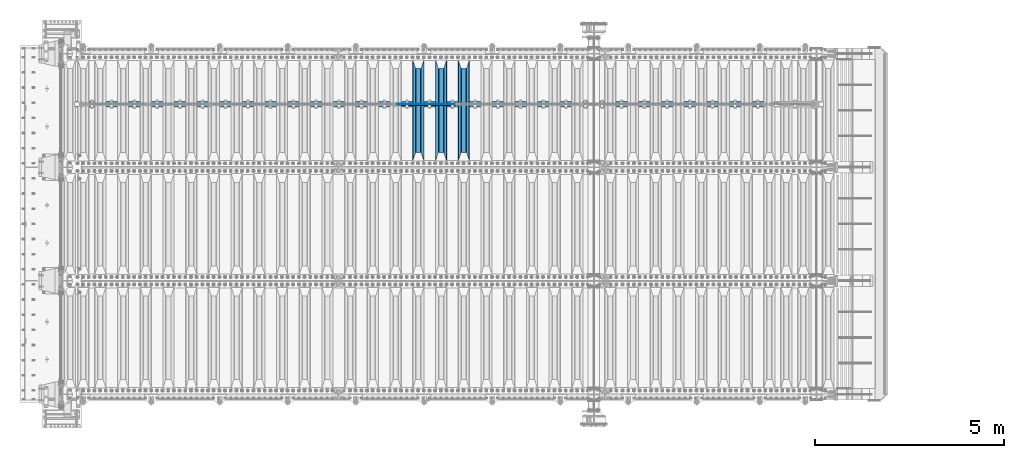
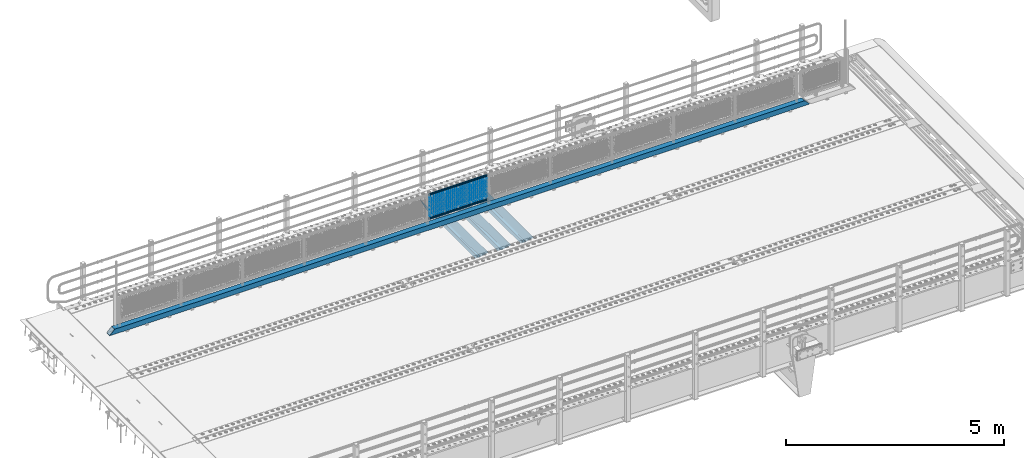
# One storey, part 134 of 270: 23 beams.
"""IFC2X3 building model written with IfcOpenShell, lengths in millimetres."""

from ifc_helpers import new_model, si_unit, frame, origin_with_axes, place, context, subcontext, project, spatial, faceted_brep, material, type_object, element, save


model = new_model("IFC2X3")

# Units and contexts
model_context = context("Model", 3, precision=1e-05, world=origin_with_axes())
body_context = subcontext(model_context, "Body", "Model", "MODEL_VIEW")
ifc_project = project(units=[si_unit("LENGTHUNIT", "METRE", prefix="MILLI"), si_unit("AREAUNIT", "SQUARE_METRE"), si_unit("VOLUMEUNIT", "CUBIC_METRE"), si_unit("MASSUNIT", "GRAM", prefix="KILO"), si_unit("TIMEUNIT", "SECOND"), si_unit("PLANEANGLEUNIT", "RADIAN"), si_unit("SOLIDANGLEUNIT", "STERADIAN"), si_unit("THERMODYNAMICTEMPERATUREUNIT", "DEGREE_CELSIUS"), si_unit("LUMINOUSINTENSITYUNIT", "LUMEN")], contexts=[model_context])

# Site, building, storey
site_placement = place(None, origin_with_axes())
site = spatial("IfcSite", under=ifc_project, at=site_placement, CompositionType="ELEMENT")
building_placement = place(site_placement, origin_with_axes())
building = spatial("IfcBuilding", under=site, at=building_placement, Name="Standard", CompositionType="ELEMENT")
storey_placement = place(building_placement, origin_with_axes())
storey = spatial("IfcBuildingStorey", under=building, at=storey_placement, Name="Undefined", CompositionType="ELEMENT", Elevation=0.0)

# Beams
ifc_material_1 = material(Name="STEEL/S355N")
beam_type_1 = type_object("IfcBeamType", PredefinedType="NOTDEFINED")
beam_1_placement = place(storey_placement, frame((10600.0, -17825.0, -115.0), z_axis=(0.0, 0.0, 1.0), x_axis=(0.0, 1.0, 0.0)))
element("IfcBeam", 1, at=beam_1_placement, inside=storey, type_object=beam_type_1, material=ifc_material_1, context=body_context, shape_type="Brep", body=[
    faceted_brep([(0.0, 150.0, 115.0), (0.0, 143.689999999999, 115.0), (2650.00000000297, 143.689999999999, 115.0), (2650.00000000297, 150.0, 115.0), (2650.00000000297, 142.059565218398, 110.000000003096), (2650.00000000297, 148.3695652184, 110.000000003096), (2441.90079219209, -80.1103600731112, -98.0992078077845), (2437.7588105432, -77.5672621345584, -102.241189456673), (2434.06523489747, -74.4080125315522, -105.934765102404), (2430.9108609509, -70.710272125576, -109.089139048974), (2428.37322971128, -66.5649389910068, -111.626770288588), (2426.51472138055, -62.0739139532889, -113.485278619323), (2425.38102192092, -57.3475956567672, -114.618978078955), (2424.99999999987, -52.5021667386536, -115.0), (2424.99999999987, 52.5021667386536, -115.0), (2425.38102192092, 57.3475956567672, -114.618978078955), (2426.51472138055, 62.0739139532889, -113.485278619323), (2428.37322971128, 66.5649389910068, -111.626770288588), (2430.9108609509, 70.710272125576, -109.089139048974), (2434.06523489747, 74.4080125315522, -105.934765102404), (2437.7588105432, 77.5672621345584, -102.241189456673), (2441.90079219209, 80.1103600731112, -98.0992078077846), (2446.38936140511, 81.9747917625791, -93.6106385947584), (2448.2494850041, 76.2713538057251, -91.7505149957729), (2444.62967112263, 74.76777986261, -95.3703288772456), (2441.28936334126, 72.7168944282894, -98.710636658607), (2438.31067330439, 70.1691124903846, -101.689326695487), (2435.76682334747, 67.1870637758839, -104.233176652398), (2433.72034654133, 63.8440531834895, -106.279653458539), (2432.22154950042, 60.222258798236, -107.778450499454), (2431.30727574265, 56.4107117849089, -108.692724257221), (2430.99999999987, 52.5031078186876, -109.0), (2430.99999999987, -52.5031078186876, -109.0), (2431.30727574265, -56.4107117849089, -108.692724257221), (2432.22154950042, -60.222258798236, -107.778450499454), (2433.72034654133, -63.8440531834895, -106.279653458539), (2435.76682334747, -67.1870637758839, -104.233176652398), (2438.31067330438, -70.1691124903846, -101.689326695487), (2441.28936334126, -72.7168944282894, -98.7106366586071), (2444.62967112263, -74.76777986261, -95.3703288772457), (2448.2494850041, -76.2713538057251, -91.7505149957729), (2650.00000000297, -142.059565218398, 110.000000003096), (2650.00000000297, -148.3695652184, 110.000000003096), (2446.38936140511, -81.9747917625791, -93.6106385947584), (2650.00000000297, -143.689999999999, 115.0), (2650.00000000297, -150.0, 115.0), (0.0, -143.689999999999, 115.0), (0.0, -150.0, 115.0), (0.0, -148.369565218261, 110.000000002672), (203.610638597431, -81.9747917625791, -93.6106385947584), (208.099207810457, -80.1103600731112, -98.0992078077845), (212.241189459342, -77.5672621345584, -102.241189456673), (215.934765105078, -74.4080125315522, -105.934765102404), (219.089139051644, -70.710272125576, -109.089139048974), (221.626770291259, -66.5649389910068, -111.626770288588), (223.485278621993, -62.0739139532889, -113.485278619323), (224.618978081628, -57.3475956567672, -114.618978078955), (225.00000000267, -52.5021667386536, -115.0), (225.00000000267, 52.5021667386536, -115.0), (224.618978081628, 57.3475956567672, -114.618978078955), (223.485278621993, 62.0739139532889, -113.485278619323), (221.626770291259, 66.5649389910068, -111.626770288588), (219.089139051644, 70.710272125576, -109.089139048974), (215.934765105078, 74.4080125315522, -105.934765102404), (212.241189459342, 77.5672621345584, -102.241189456673), (208.099207810457, 80.1103600731112, -98.0992078077846), (203.610638597431, 81.9747917625791, -93.6106385947584), (0.0, 148.369565218261, 110.000000002672), (0.0, 142.05956521826, 110.000000002672), (201.750514998446, 76.2713538057251, -91.7505149957729), (205.370328879915, 74.76777986261, -95.3703288772456), (208.710636661279, 72.7168944282894, -98.710636658607), (211.689326698157, 70.1691124903846, -101.689326695487), (214.233176655071, 67.1870637758839, -104.233176652398), (216.27965346121, 63.8440531834895, -106.279653458539), (217.778450502126, 60.222258798236, -107.778450499454), (218.692724259894, 56.4107117849089, -108.692724257221), (219.00000000267, 52.5031078186876, -109.0), (219.00000000267, -52.5031078186876, -109.0), (218.692724259894, -56.4107117849089, -108.692724257221), (217.778450502123, -60.222258798236, -107.778450499454), (216.27965346121, -63.8440531834895, -106.279653458539), (214.233176655071, -67.1870637758839, -104.233176652398), (211.689326698157, -70.1691124903846, -101.689326695487), (208.710636661279, -72.7168944282894, -98.7106366586071), (205.370328879915, -74.76777986261, -95.3703288772457), (201.750514998446, -76.2713538057251, -91.7505149957729), (0.0, -142.05956521826, 110.000000002672)], [[[0, 1, 2, 3]], [[3, 2, 4, 5]], [[6, 7, 8, 9, 10, 11, 12, 13, 14, 15, 16, 17, 18, 19, 20, 21, 22, 5, 4, 23, 24, 25, 26, 27, 28, 29, 30, 31, 32, 33, 34, 35, 36, 37, 38, 39, 40, 41, 42, 43]], [[44, 45, 42, 41]], [[46, 47, 45, 44]], [[43, 42, 45, 47, 48, 49]], [[6, 43, 49, 50]], [[7, 6, 50, 51]], [[8, 7, 51, 52]], [[9, 8, 52, 53]], [[10, 9, 53, 54]], [[11, 10, 54, 55]], [[12, 11, 55, 56]], [[13, 12, 56, 57]], [[14, 13, 57, 58]], [[15, 14, 58, 59]], [[16, 15, 59, 60]], [[17, 16, 60, 61]], [[18, 17, 61, 62]], [[19, 18, 62, 63]], [[20, 19, 63, 64]], [[21, 20, 64, 65]], [[22, 21, 65, 66]], [[0, 3, 5, 22, 66, 67]], [[1, 0, 67, 68]], [[23, 4, 2, 1, 68, 69]], [[24, 23, 69, 70]], [[25, 24, 70, 71]], [[26, 25, 71, 72]], [[27, 26, 72, 73]], [[28, 27, 73, 74]], [[29, 28, 74, 75]], [[30, 29, 75, 76]], [[31, 30, 76, 77]], [[32, 31, 77, 78]], [[33, 32, 78, 79]], [[34, 33, 79, 80]], [[35, 34, 80, 81]], [[36, 35, 81, 82]], [[37, 36, 82, 83]], [[38, 37, 83, 84]], [[39, 38, 84, 85]], [[40, 39, 85, 86]], [[46, 44, 41, 40, 86, 87]], [[47, 46, 87, 48]], [[86, 85, 84, 83, 82, 81, 80, 79, 78, 77, 76, 75, 74, 73, 72, 71, 70, 69, 68, 67, 66, 65, 64, 63, 62, 61, 60, 59, 58, 57, 56, 55, 54, 53, 52, 51, 50, 49, 48, 87]]]),
])
beam_2_placement = place(storey_placement, frame((10000.0, -17825.0, -115.0), z_axis=(0.0, 0.0, 1.0), x_axis=(0.0, 1.0, 0.0)))
element("IfcBeam", 2, at=beam_2_placement, inside=storey, type_object=beam_type_1, material=ifc_material_1, context=body_context, shape_type="Brep", body=[
    faceted_brep([(0.0, 150.0, 115.0), (0.0, 143.689999999999, 115.0), (2650.00000000297, 143.689999999999, 115.0), (2650.00000000297, 150.0, 115.0), (2650.00000000297, 142.059565218398, 110.000000003096), (2650.00000000297, 148.3695652184, 110.000000003096), (2441.90079219209, -80.1103600731112, -98.0992078077845), (2437.7588105432, -77.5672621345584, -102.241189456673), (2434.06523489747, -74.4080125315522, -105.934765102404), (2430.9108609509, -70.710272125576, -109.089139048974), (2428.37322971128, -66.5649389910068, -111.626770288588), (2426.51472138055, -62.0739139532889, -113.485278619323), (2425.38102192092, -57.3475956567672, -114.618978078955), (2424.99999999987, -52.5021667386536, -115.0), (2424.99999999987, 52.5021667386536, -115.0), (2425.38102192092, 57.3475956567672, -114.618978078955), (2426.51472138055, 62.0739139532889, -113.485278619323), (2428.37322971128, 66.5649389910068, -111.626770288588), (2430.9108609509, 70.710272125576, -109.089139048974), (2434.06523489747, 74.4080125315522, -105.934765102404), (2437.7588105432, 77.5672621345584, -102.241189456673), (2441.90079219209, 80.1103600731112, -98.0992078077846), (2446.38936140511, 81.9747917625791, -93.6106385947584), (2448.2494850041, 76.2713538057251, -91.7505149957729), (2444.62967112263, 74.76777986261, -95.3703288772456), (2441.28936334126, 72.7168944282894, -98.710636658607), (2438.31067330439, 70.1691124903846, -101.689326695487), (2435.76682334747, 67.1870637758839, -104.233176652398), (2433.72034654133, 63.8440531834895, -106.279653458539), (2432.22154950042, 60.222258798236, -107.778450499454), (2431.30727574265, 56.4107117849089, -108.692724257221), (2430.99999999987, 52.5031078186876, -109.0), (2430.99999999987, -52.5031078186876, -109.0), (2431.30727574265, -56.4107117849089, -108.692724257221), (2432.22154950042, -60.222258798236, -107.778450499454), (2433.72034654133, -63.8440531834895, -106.279653458539), (2435.76682334747, -67.1870637758839, -104.233176652398), (2438.31067330438, -70.1691124903846, -101.689326695487), (2441.28936334126, -72.7168944282894, -98.7106366586071), (2444.62967112263, -74.76777986261, -95.3703288772457), (2448.2494850041, -76.2713538057251, -91.7505149957729), (2650.00000000297, -142.059565218398, 110.000000003096), (2650.00000000297, -148.3695652184, 110.000000003096), (2446.38936140511, -81.9747917625791, -93.6106385947584), (2650.00000000297, -143.689999999999, 115.0), (2650.00000000297, -150.0, 115.0), (0.0, -143.689999999999, 115.0), (0.0, -150.0, 115.0), (0.0, -148.369565218261, 110.000000002672), (203.610638597431, -81.9747917625791, -93.6106385947584), (208.099207810457, -80.1103600731112, -98.0992078077845), (212.241189459342, -77.5672621345584, -102.241189456673), (215.934765105078, -74.4080125315522, -105.934765102404), (219.089139051644, -70.710272125576, -109.089139048974), (221.626770291259, -66.5649389910068, -111.626770288588), (223.485278621993, -62.0739139532889, -113.485278619323), (224.618978081628, -57.3475956567672, -114.618978078955), (225.00000000267, -52.5021667386536, -115.0), (225.00000000267, 52.5021667386536, -115.0), (224.618978081628, 57.3475956567672, -114.618978078955), (223.485278621993, 62.0739139532889, -113.485278619323), (221.626770291259, 66.5649389910068, -111.626770288588), (219.089139051644, 70.710272125576, -109.089139048974), (215.934765105078, 74.4080125315522, -105.934765102404), (212.241189459342, 77.5672621345584, -102.241189456673), (208.099207810457, 80.1103600731112, -98.0992078077846), (203.610638597431, 81.9747917625791, -93.6106385947584), (0.0, 148.369565218261, 110.000000002672), (0.0, 142.05956521826, 110.000000002672), (201.750514998446, 76.2713538057251, -91.7505149957729), (205.370328879915, 74.76777986261, -95.3703288772456), (208.710636661279, 72.7168944282894, -98.710636658607), (211.689326698157, 70.1691124903846, -101.689326695487), (214.233176655071, 67.1870637758839, -104.233176652398), (216.27965346121, 63.8440531834895, -106.279653458539), (217.778450502126, 60.222258798236, -107.778450499454), (218.692724259894, 56.4107117849089, -108.692724257221), (219.00000000267, 52.5031078186876, -109.0), (219.00000000267, -52.5031078186876, -109.0), (218.692724259894, -56.4107117849089, -108.692724257221), (217.778450502123, -60.222258798236, -107.778450499454), (216.27965346121, -63.8440531834895, -106.279653458539), (214.233176655071, -67.1870637758839, -104.233176652398), (211.689326698157, -70.1691124903846, -101.689326695487), (208.710636661279, -72.7168944282894, -98.7106366586071), (205.370328879915, -74.76777986261, -95.3703288772457), (201.750514998446, -76.2713538057251, -91.7505149957729), (0.0, -142.05956521826, 110.000000002672)], [[[0, 1, 2, 3]], [[3, 2, 4, 5]], [[6, 7, 8, 9, 10, 11, 12, 13, 14, 15, 16, 17, 18, 19, 20, 21, 22, 5, 4, 23, 24, 25, 26, 27, 28, 29, 30, 31, 32, 33, 34, 35, 36, 37, 38, 39, 40, 41, 42, 43]], [[44, 45, 42, 41]], [[46, 47, 45, 44]], [[43, 42, 45, 47, 48, 49]], [[6, 43, 49, 50]], [[7, 6, 50, 51]], [[8, 7, 51, 52]], [[9, 8, 52, 53]], [[10, 9, 53, 54]], [[11, 10, 54, 55]], [[12, 11, 55, 56]], [[13, 12, 56, 57]], [[14, 13, 57, 58]], [[15, 14, 58, 59]], [[16, 15, 59, 60]], [[17, 16, 60, 61]], [[18, 17, 61, 62]], [[19, 18, 62, 63]], [[20, 19, 63, 64]], [[21, 20, 64, 65]], [[22, 21, 65, 66]], [[0, 3, 5, 22, 66, 67]], [[1, 0, 67, 68]], [[23, 4, 2, 1, 68, 69]], [[24, 23, 69, 70]], [[25, 24, 70, 71]], [[26, 25, 71, 72]], [[27, 26, 72, 73]], [[28, 27, 73, 74]], [[29, 28, 74, 75]], [[30, 29, 75, 76]], [[31, 30, 76, 77]], [[32, 31, 77, 78]], [[33, 32, 78, 79]], [[34, 33, 79, 80]], [[35, 34, 80, 81]], [[36, 35, 81, 82]], [[37, 36, 82, 83]], [[38, 37, 83, 84]], [[39, 38, 84, 85]], [[40, 39, 85, 86]], [[46, 44, 41, 40, 86, 87]], [[47, 46, 87, 48]], [[86, 85, 84, 83, 82, 81, 80, 79, 78, 77, 76, 75, 74, 73, 72, 71, 70, 69, 68, 67, 66, 65, 64, 63, 62, 61, 60, 59, 58, 57, 56, 55, 54, 53, 52, 51, 50, 49, 48, 87]]]),
])
beam_3_placement = place(storey_placement, frame((9400.0, -17825.0, -115.0), z_axis=(0.0, 0.0, 1.0), x_axis=(0.0, 1.0, 0.0)))
element("IfcBeam", 3, at=beam_3_placement, inside=storey, type_object=beam_type_1, material=ifc_material_1, context=body_context, shape_type="Brep", body=[
    faceted_brep([(0.0, 150.0, 115.0), (0.0, 143.689999999999, 115.0), (2650.00000000297, 143.689999999999, 115.0), (2650.00000000297, 150.0, 115.0), (2650.00000000297, 142.059565218398, 110.000000003096), (2650.00000000297, 148.3695652184, 110.000000003096), (2441.90079219209, -80.1103600731112, -98.0992078077845), (2437.7588105432, -77.5672621345584, -102.241189456673), (2434.06523489747, -74.4080125315522, -105.934765102404), (2430.9108609509, -70.710272125576, -109.089139048974), (2428.37322971128, -66.5649389910068, -111.626770288588), (2426.51472138055, -62.0739139532889, -113.485278619323), (2425.38102192092, -57.3475956567672, -114.618978078955), (2424.99999999987, -52.5021667386536, -115.0), (2424.99999999987, 52.5021667386536, -115.0), (2425.38102192092, 57.3475956567672, -114.618978078955), (2426.51472138055, 62.0739139532889, -113.485278619323), (2428.37322971128, 66.5649389910068, -111.626770288588), (2430.9108609509, 70.710272125576, -109.089139048974), (2434.06523489747, 74.4080125315522, -105.934765102404), (2437.7588105432, 77.5672621345584, -102.241189456673), (2441.90079219209, 80.1103600731112, -98.0992078077846), (2446.38936140511, 81.9747917625791, -93.6106385947584), (2448.2494850041, 76.2713538057251, -91.7505149957729), (2444.62967112263, 74.76777986261, -95.3703288772456), (2441.28936334126, 72.7168944282894, -98.710636658607), (2438.31067330439, 70.1691124903846, -101.689326695487), (2435.76682334747, 67.1870637758839, -104.233176652398), (2433.72034654133, 63.8440531834895, -106.279653458539), (2432.22154950042, 60.222258798236, -107.778450499454), (2431.30727574265, 56.4107117849089, -108.692724257221), (2430.99999999987, 52.5031078186876, -109.0), (2430.99999999987, -52.5031078186876, -109.0), (2431.30727574265, -56.4107117849089, -108.692724257221), (2432.22154950042, -60.222258798236, -107.778450499454), (2433.72034654133, -63.8440531834895, -106.279653458539), (2435.76682334747, -67.1870637758839, -104.233176652398), (2438.31067330438, -70.1691124903846, -101.689326695487), (2441.28936334126, -72.7168944282894, -98.7106366586071), (2444.62967112263, -74.76777986261, -95.3703288772457), (2448.2494850041, -76.2713538057251, -91.7505149957729), (2650.00000000297, -142.059565218398, 110.000000003096), (2650.00000000297, -148.3695652184, 110.000000003096), (2446.38936140511, -81.9747917625791, -93.6106385947584), (2650.00000000297, -143.689999999999, 115.0), (2650.00000000297, -150.0, 115.0), (0.0, -143.689999999999, 115.0), (0.0, -150.0, 115.0), (0.0, -148.369565218261, 110.000000002672), (203.610638597431, -81.9747917625791, -93.6106385947584), (208.099207810457, -80.1103600731112, -98.0992078077845), (212.241189459342, -77.5672621345584, -102.241189456673), (215.934765105078, -74.4080125315522, -105.934765102404), (219.089139051644, -70.710272125576, -109.089139048974), (221.626770291259, -66.5649389910068, -111.626770288588), (223.485278621993, -62.0739139532889, -113.485278619323), (224.618978081628, -57.3475956567672, -114.618978078955), (225.00000000267, -52.5021667386536, -115.0), (225.00000000267, 52.5021667386536, -115.0), (224.618978081628, 57.3475956567672, -114.618978078955), (223.485278621993, 62.0739139532889, -113.485278619323), (221.626770291259, 66.5649389910068, -111.626770288588), (219.089139051644, 70.710272125576, -109.089139048974), (215.934765105078, 74.4080125315522, -105.934765102404), (212.241189459342, 77.5672621345584, -102.241189456673), (208.099207810457, 80.1103600731112, -98.0992078077846), (203.610638597431, 81.9747917625791, -93.6106385947584), (0.0, 148.369565218261, 110.000000002672), (0.0, 142.05956521826, 110.000000002672), (201.750514998446, 76.2713538057251, -91.7505149957729), (205.370328879915, 74.76777986261, -95.3703288772456), (208.710636661279, 72.7168944282894, -98.710636658607), (211.689326698157, 70.1691124903846, -101.689326695487), (214.233176655071, 67.1870637758839, -104.233176652398), (216.27965346121, 63.8440531834895, -106.279653458539), (217.778450502126, 60.222258798236, -107.778450499454), (218.692724259894, 56.4107117849089, -108.692724257221), (219.00000000267, 52.5031078186876, -109.0), (219.00000000267, -52.5031078186876, -109.0), (218.692724259894, -56.4107117849089, -108.692724257221), (217.778450502123, -60.222258798236, -107.778450499454), (216.27965346121, -63.8440531834895, -106.279653458539), (214.233176655071, -67.1870637758839, -104.233176652398), (211.689326698157, -70.1691124903846, -101.689326695487), (208.710636661279, -72.7168944282894, -98.7106366586071), (205.370328879915, -74.76777986261, -95.3703288772457), (201.750514998446, -76.2713538057251, -91.7505149957729), (0.0, -142.05956521826, 110.000000002672)], [[[0, 1, 2, 3]], [[3, 2, 4, 5]], [[6, 7, 8, 9, 10, 11, 12, 13, 14, 15, 16, 17, 18, 19, 20, 21, 22, 5, 4, 23, 24, 25, 26, 27, 28, 29, 30, 31, 32, 33, 34, 35, 36, 37, 38, 39, 40, 41, 42, 43]], [[44, 45, 42, 41]], [[46, 47, 45, 44]], [[43, 42, 45, 47, 48, 49]], [[6, 43, 49, 50]], [[7, 6, 50, 51]], [[8, 7, 51, 52]], [[9, 8, 52, 53]], [[10, 9, 53, 54]], [[11, 10, 54, 55]], [[12, 11, 55, 56]], [[13, 12, 56, 57]], [[14, 13, 57, 58]], [[15, 14, 58, 59]], [[16, 15, 59, 60]], [[17, 16, 60, 61]], [[18, 17, 61, 62]], [[19, 18, 62, 63]], [[20, 19, 63, 64]], [[21, 20, 64, 65]], [[22, 21, 65, 66]], [[0, 3, 5, 22, 66, 67]], [[1, 0, 67, 68]], [[23, 4, 2, 1, 68, 69]], [[24, 23, 69, 70]], [[25, 24, 70, 71]], [[26, 25, 71, 72]], [[27, 26, 72, 73]], [[28, 27, 73, 74]], [[29, 28, 74, 75]], [[30, 29, 75, 76]], [[31, 30, 76, 77]], [[32, 31, 77, 78]], [[33, 32, 78, 79]], [[34, 33, 79, 80]], [[35, 34, 80, 81]], [[36, 35, 81, 82]], [[37, 36, 82, 83]], [[38, 37, 83, 84]], [[39, 38, 84, 85]], [[40, 39, 85, 86]], [[46, 44, 41, 40, 86, 87]], [[47, 46, 87, 48]], [[86, 85, 84, 83, 82, 81, 80, 79, 78, 77, 76, 75, 74, 73, 72, 71, 70, 69, 68, 67, 66, 65, 64, 63, 62, 61, 60, 59, 58, 57, 56, 55, 54, 53, 52, 51, 50, 49, 48, 87]]]),
])
ifc_material_2 = material()
beam_type_2 = type_object("IfcBeamType", PredefinedType="NOTDEFINED")
beam_4_placement = place(storey_placement, frame((325.0, -16335.5, 98.0199999999977), z_axis=(0.0, 0.0, 1.0), x_axis=(1.0, 0.0, 0.0)))
element("IfcBeam", 4, at=beam_4_placement, inside=storey, type_object=beam_type_2, material=ifc_material_2, context=body_context, shape_type="Brep", body=[
    faceted_brep([(0.0, -70.0, -70.0), (0.0, 70.0, -70.0), (18565.0, 70.0, -70.0), (18565.0, -70.0, -70.0), (18434.8884698478, -70.0, 70.0), (18434.8884698478, 70.0, 70.0), (130.111530936145, 70.0, 70.0), (130.11152897614, -70.0, 70.0), (18565.0, -70.0, -60.0079600980745), (0.0, -70.0, -60.0079591069113), (18444.8964362873, -60.0, 60.0), (18565.0, -60.0, -60.0), (0.0, -60.0, -60.0), (120.103562690863, -60.0, 60.0), (18444.8964362873, 60.0, 60.0), (120.10356437086, 60.0, 60.0), (18565.0, 60.0, -60.0), (0.0, 60.0, -60.0), (18565.0, 70.0, -60.0079600980745), (0.0, 70.0, -60.0079610653512)], [[[0, 1, 2, 3]], [[4, 5, 6, 7]], [[0, 3, 8, 4, 7, 9]], [[10, 11, 12, 13]], [[14, 10, 13, 15]], [[16, 14, 15, 17]], [[4, 8, 11, 10, 14, 16, 18, 5]], [[11, 8, 3, 2, 18, 16]], [[17, 12, 11, 16]], [[1, 0, 9, 12, 17, 19]], [[5, 18, 2, 1, 19, 6]], [[17, 15, 13, 12, 9, 7, 6, 19]]]),
])
ifc_material_3 = material(Name="Misc_Undefined")
beam_type_3 = type_object("IfcBeamType", Name="D3", PredefinedType="NOTDEFINED")
for number, where, z_axis, x_axis in (
    (5, (8841.0, -16329.5, 851.596999999999), (0.0, 0.0, 1.0), (1.0, 0.0, 0.0)),
    (6, (8841.0, -16329.5, 669.452), (0.0, 0.0, 1.0), (1.0, 0.0, 0.0)),
    (7, (8841.0, -16329.5, 523.736), (0.0, 0.0, 1.0), (1.0, 0.0, 0.0)),
    (8, (8841.0, -16329.5, 487.307), (0.0, 0.0, 1.0), (1.0, 0.0, 0.0)),
    (9, (8841.0, -16329.5, 705.881), (0.0, 0.0, 1.0), (1.0, 0.0, 0.0)),
    (10, (8841.0, -16329.5, 596.594), (0.0, 0.0, 1.0), (1.0, 0.0, 0.0)),
    (11, (8841.0, -16329.5, 450.878), (0.0, 0.0, 1.0), (1.0, 0.0, 0.0)),
    (12, (8841.0, -16329.5, 815.167999999999), (0.0, 0.0, 1.0), (1.0, 0.0, 0.0)),
    (13, (8841.0, -16329.5, 888.025999999999), (0.0, 0.0, 1.0), (1.0, 0.0, 0.0)),
    (14, (8841.0, -16329.5, 778.738999999999), (0.0, 0.0, 1.0), (1.0, 0.0, 0.0)),
    (15, (8841.0, -16329.5, 742.309999999999), (0.0, 0.0, 1.0), (1.0, 0.0, 0.0)),
    (16, (8841.0, -16329.5, 633.023), (0.0, 0.0, 1.0), (1.0, 0.0, 0.0)),
    (17, (8841.0, -16329.5, 560.165), (0.0, 0.0, 1.0), (1.0, 0.0, 0.0)),
    (18, (8841.0, -16329.5, 414.449), (0.0, 0.0, 1.0), (1.0, 0.0, 0.0)),
):
    element("IfcBeam", number, at=place(storey_placement, frame(where, z_axis=z_axis, x_axis=x_axis)), inside=storey, type_object=beam_type_3, material=ifc_material_3, ObjectType="D3", context=body_context, shape_type="Brep", body=[
        faceted_brep([(0.0, -1.5, 0.0), (0.0, -0.75, -1.29903810567669), (1523.0, -0.75, -1.29903810567669), (1523.0, -1.5, 0.0), (0.0, 0.75, -1.29903810567669), (1523.0, 0.75, -1.29903810567669), (0.0, 1.5, 0.0), (1523.0, 1.5, 0.0), (0.0, 0.75, 1.29903810567669), (1523.0, 0.75, 1.29903810567669), (0.0, -0.75, 1.29903810567669), (1523.0, -0.75, 1.29903810567669)], [[[0, 1, 2, 3]], [[1, 4, 5, 2]], [[4, 6, 7, 5]], [[6, 8, 9, 7]], [[8, 10, 11, 9]], [[10, 0, 3, 11]], [[5, 7, 9, 11, 3, 2]], [[10, 8, 6, 4, 1, 0]]]),
    ])
beam_5_placement = place(storey_placement, frame((8866.0, -16329.5, 353.02), z_axis=(0.0, 0.0, 1.0), x_axis=(1.0, 0.0, 0.0)))
element("IfcBeam", 19, at=beam_5_placement, inside=storey, type_object=beam_type_3, material=ifc_material_3, ObjectType="D3", context=body_context, shape_type="Brep", body=[
    faceted_brep([(0.0, -1.5, 0.0), (0.0, -0.75, -1.29903810567669), (1473.0, -0.75, -1.29903810567669), (1473.0, -1.5, 0.0), (0.0, 0.75, -1.29903810567669), (1473.0, 0.75, -1.29903810567663), (0.0, 1.5, 0.0), (1473.0, 1.5, 0.0), (0.0, 0.75, 1.29903810567669), (1473.0, 0.75, 1.29903810567669), (0.0, -0.75, 1.29903810567669), (1473.0, -0.75, 1.29903810567669)], [[[0, 1, 2, 3]], [[1, 4, 5, 2]], [[4, 6, 7, 5]], [[6, 8, 9, 7]], [[8, 10, 11, 9]], [[10, 0, 3, 11]], [[5, 7, 9, 11, 3, 2]], [[10, 8, 6, 4, 1, 0]]]),
])
beam_6_placement = place(storey_placement, frame((8841.0, -16329.5, 378.02), z_axis=(0.0, 0.0, 1.0), x_axis=(1.0, 0.0, 0.0)))
element("IfcBeam", 20, at=beam_6_placement, inside=storey, type_object=beam_type_3, material=ifc_material_3, ObjectType="D3", context=body_context, shape_type="Brep", body=[
    faceted_brep([(0.0, -1.5, 0.0), (0.0, -0.75, -1.29903810567669), (1523.0, -0.75, -1.29903810567669), (1523.0, -1.5, 0.0), (0.0, 0.75, -1.29903810567669), (1523.0, 0.75, -1.29903810567669), (0.0, 1.5, 0.0), (1523.0, 1.5, 0.0), (0.0, 0.75, 1.29903810567669), (1523.0, 0.75, 1.29903810567669), (0.0, -0.75, 1.29903810567669), (1523.0, -0.75, 1.29903810567669)], [[[0, 1, 2, 3]], [[1, 4, 5, 2]], [[4, 6, 7, 5]], [[6, 8, 9, 7]], [[8, 10, 11, 9]], [[10, 0, 3, 11]], [[5, 7, 9, 11, 3, 2]], [[10, 8, 6, 4, 1, 0]]]),
])
beam_7_placement = place(storey_placement, frame((8866.0, -16329.5, 913.02), z_axis=(0.0, 0.0, 1.0), x_axis=(1.0, 0.0, 0.0)))
element("IfcBeam", 21, at=beam_7_placement, inside=storey, type_object=beam_type_3, material=ifc_material_3, ObjectType="D3", context=body_context, shape_type="Brep", body=[
    faceted_brep([(0.0, -1.5, 0.0), (0.0, -0.75, -1.29903810567669), (1473.0, -0.75, -1.29903810567669), (1473.0, -1.5, 0.0), (0.0, 0.75, -1.29903810567669), (1473.0, 0.75, -1.29903810567663), (0.0, 1.5, 0.0), (1473.0, 1.5, 0.0), (0.0, 0.75, 1.29903810567669), (1473.0, 0.75, 1.29903810567669), (0.0, -0.75, 1.29903810567669), (1473.0, -0.75, 1.29903810567669)], [[[0, 1, 2, 3]], [[1, 4, 5, 2]], [[4, 6, 7, 5]], [[6, 8, 9, 7]], [[8, 10, 11, 9]], [[10, 0, 3, 11]], [[5, 7, 9, 11, 3, 2]], [[10, 8, 6, 4, 1, 0]]]),
])
beam_type_4 = type_object("IfcBeamType", PredefinedType="NOTDEFINED")
beam_8_placement = place(storey_placement, frame((8820.85, -16335.5, 969.849999999999), z_axis=(0.0, 0.0, 1.0), x_axis=(1.0, 0.0, 0.0)))
element("IfcBeam", 22, at=beam_8_placement, inside=storey, type_object=beam_type_4, material=ifc_material_2, context=body_context, shape_type="Brep", body=[
    faceted_brep([(0.0, -25.3500000000004, 0.0), (0.0, -23.4203461491616, 9.70102501045403), (1563.0, -23.4203461491616, 9.70102501045506), (1563.0, -25.3500000000004, 0.0), (0.0, -17.9251569030785, 17.9251569030785), (1563.0, -17.9251569030785, 17.925156903079), (0.0, -9.70102501045585, 23.4203461491597), (1563.0, -9.70102501045585, 23.4203461491611), (0.0, 0.0, 25.3499999999985), (1563.0, 0.0, 25.35), (0.0, 9.70102501045585, 23.4203461491597), (1563.0, 9.70102501045585, 23.4203461491611), (0.0, 17.9251569030785, 17.9251569030785), (1563.0, 17.9251569030785, 17.925156903079), (0.0, 23.4203461491616, 9.70102501045403), (1563.0, 23.4203461491616, 9.70102501045506), (0.0, 25.3500000000004, 0.0), (1563.0, 25.3500000000004, 0.0), (0.0, 23.4203461491616, -9.70102501045403), (1563.0, 23.4203461491616, -9.70102501045506), (0.0, 17.9251569030785, -17.9251569030785), (1563.0, 17.9251569030785, -17.925156903079), (0.0, 9.70102501045585, -23.4203461491597), (1563.0, 9.70102501045585, -23.4203461491611), (0.0, 0.0, -25.3499999999985), (1563.0, 0.0, -25.35), (0.0, -9.70102501045585, -23.4203461491597), (1563.0, -9.70102501045585, -23.4203461491611), (0.0, -17.9251569030785, -17.9251569030785), (1563.0, -17.9251569030785, -17.925156903079), (0.0, -23.4203461491616, -9.70102501045403), (1563.0, -23.4203461491616, -9.70102501045506), (0.0, -30.1499999999996, 0.0), (0.0, -27.8549679052157, -11.5379054858058), (1563.0, -27.8549679052157, -11.5379054858075), (1563.0, -30.1499999999996, 0.0), (0.0, -21.3192694527752, -21.3192694527752), (1563.0, -21.3192694527752, -21.3192694527744), (0.0, -11.5379054858076, -27.8549679052157), (1563.0, -11.5379054858076, -27.8549679052153), (0.0, 0.0, -30.1500000000015), (1563.0, 0.0, -30.15), (0.0, 11.5379054858076, -27.8549679052157), (1563.0, 11.5379054858076, -27.8549679052153), (0.0, 21.3192694527752, -21.3192694527752), (1563.0, 21.3192694527752, -21.3192694527744), (0.0, 27.8549679052157, -11.5379054858058), (1563.0, 27.8549679052157, -11.5379054858074), (0.0, 30.1499999999996, 0.0), (1563.0, 30.1499999999996, 0.0), (0.0, 27.8549679052157, 11.5379054858058), (1563.0, 27.8549679052157, 11.5379054858074), (0.0, 21.3192694527752, 21.3192694527752), (1563.0, 21.3192694527752, 21.3192694527744), (0.0, 11.5379054858076, 27.8549679052157), (1563.0, 11.5379054858076, 27.8549679052153), (0.0, 0.0, 30.1500000000015), (1563.0, 0.0, 30.15), (0.0, -11.5379054858076, 27.8549679052157), (1563.0, -11.5379054858076, 27.8549679052153), (0.0, -21.3192694527752, 21.3192694527752), (1563.0, -21.3192694527752, 21.3192694527744), (0.0, -27.8549679052157, 11.5379054858058), (1563.0, -27.8549679052157, 11.5379054858074)], [[[0, 1, 2, 3]], [[1, 4, 5, 2]], [[4, 6, 7, 5]], [[6, 8, 9, 7]], [[8, 10, 11, 9]], [[10, 12, 13, 11]], [[12, 14, 15, 13]], [[14, 16, 17, 15]], [[16, 18, 19, 17]], [[18, 20, 21, 19]], [[20, 22, 23, 21]], [[22, 24, 25, 23]], [[24, 26, 27, 25]], [[26, 28, 29, 27]], [[28, 30, 31, 29]], [[30, 0, 3, 31]], [[32, 33, 34, 35]], [[33, 36, 37, 34]], [[36, 38, 39, 37]], [[38, 40, 41, 39]], [[40, 42, 43, 41]], [[42, 44, 45, 43]], [[44, 46, 47, 45]], [[46, 48, 49, 47]], [[48, 50, 51, 49]], [[50, 52, 53, 51]], [[52, 54, 55, 53]], [[54, 56, 57, 55]], [[56, 58, 59, 57]], [[58, 60, 61, 59]], [[60, 62, 63, 61]], [[62, 32, 35, 63]], [[37, 39, 41, 43, 45, 47, 49, 51, 53, 55, 57, 59, 61, 63, 35, 34], [5, 7, 9, 11, 13, 15, 17, 19, 21, 23, 25, 27, 29, 31, 3, 2]], [[62, 60, 58, 56, 54, 52, 50, 48, 46, 44, 42, 40, 38, 36, 33, 32], [30, 28, 26, 24, 22, 20, 18, 16, 14, 12, 10, 8, 6, 4, 1, 0]]]),
])
beam_9_placement = place(storey_placement, frame((8820.85000000001, -16335.5, 298.170000000001), z_axis=(0.0, 0.0, 1.0), x_axis=(1.0, 0.0, 0.0)))
element("IfcBeam", 23, at=beam_9_placement, inside=storey, type_object=beam_type_4, material=ifc_material_2, context=body_context, shape_type="Brep", body=[
    faceted_brep([(0.0, -25.3500000000004, 0.0), (0.0, -23.4203461491616, 9.70102501045403), (1563.0, -23.4203461491616, 9.70102501045506), (1563.0, -25.3500000000004, 0.0), (0.0, -17.9251569030785, 17.9251569030785), (1563.0, -17.9251569030785, 17.925156903079), (0.0, -9.70102501045585, 23.4203461491597), (1563.0, -9.70102501045585, 23.4203461491611), (0.0, 0.0, 25.3499999999985), (1563.0, 0.0, 25.35), (0.0, 9.70102501045585, 23.4203461491597), (1563.0, 9.70102501045585, 23.4203461491611), (0.0, 17.9251569030785, 17.9251569030785), (1563.0, 17.9251569030785, 17.925156903079), (0.0, 23.4203461491616, 9.70102501045403), (1563.0, 23.4203461491616, 9.70102501045506), (0.0, 25.3500000000004, 0.0), (1563.0, 25.3500000000004, 0.0), (0.0, 23.4203461491616, -9.70102501045403), (1563.0, 23.4203461491616, -9.70102501045506), (0.0, 17.9251569030785, -17.9251569030785), (1563.0, 17.9251569030785, -17.925156903079), (0.0, 9.70102501045585, -23.4203461491597), (1563.0, 9.70102501045585, -23.4203461491611), (0.0, 0.0, -25.3499999999985), (1563.0, 0.0, -25.35), (0.0, -9.70102501045585, -23.4203461491597), (1563.0, -9.70102501045585, -23.4203461491611), (0.0, -17.9251569030785, -17.9251569030785), (1563.0, -17.9251569030785, -17.925156903079), (0.0, -23.4203461491616, -9.70102501045403), (1563.0, -23.4203461491616, -9.70102501045506), (0.0, -30.1499999999996, 0.0), (0.0, -27.8549679052157, -11.5379054858058), (1563.0, -27.8549679052157, -11.5379054858075), (1563.0, -30.1499999999996, 0.0), (0.0, -21.3192694527752, -21.3192694527752), (1563.0, -21.3192694527752, -21.3192694527744), (0.0, -11.5379054858076, -27.8549679052157), (1563.0, -11.5379054858076, -27.8549679052153), (0.0, 0.0, -30.1500000000015), (1563.0, 0.0, -30.15), (0.0, 11.5379054858076, -27.8549679052157), (1563.0, 11.5379054858076, -27.8549679052153), (0.0, 21.3192694527752, -21.3192694527752), (1563.0, 21.3192694527752, -21.3192694527744), (0.0, 27.8549679052157, -11.5379054858058), (1563.0, 27.8549679052157, -11.5379054858074), (0.0, 30.1499999999996, 0.0), (1563.0, 30.1499999999996, 0.0), (0.0, 27.8549679052157, 11.5379054858058), (1563.0, 27.8549679052157, 11.5379054858074), (0.0, 21.3192694527752, 21.3192694527752), (1563.0, 21.3192694527752, 21.3192694527744), (0.0, 11.5379054858076, 27.8549679052157), (1563.0, 11.5379054858076, 27.8549679052153), (0.0, 0.0, 30.1500000000015), (1563.0, 0.0, 30.15), (0.0, -11.5379054858076, 27.8549679052157), (1563.0, -11.5379054858076, 27.8549679052153), (0.0, -21.3192694527752, 21.3192694527752), (1563.0, -21.3192694527752, 21.3192694527744), (0.0, -27.8549679052157, 11.5379054858058), (1563.0, -27.8549679052157, 11.5379054858074)], [[[0, 1, 2, 3]], [[1, 4, 5, 2]], [[4, 6, 7, 5]], [[6, 8, 9, 7]], [[8, 10, 11, 9]], [[10, 12, 13, 11]], [[12, 14, 15, 13]], [[14, 16, 17, 15]], [[16, 18, 19, 17]], [[18, 20, 21, 19]], [[20, 22, 23, 21]], [[22, 24, 25, 23]], [[24, 26, 27, 25]], [[26, 28, 29, 27]], [[28, 30, 31, 29]], [[30, 0, 3, 31]], [[32, 33, 34, 35]], [[33, 36, 37, 34]], [[36, 38, 39, 37]], [[38, 40, 41, 39]], [[40, 42, 43, 41]], [[42, 44, 45, 43]], [[44, 46, 47, 45]], [[46, 48, 49, 47]], [[48, 50, 51, 49]], [[50, 52, 53, 51]], [[52, 54, 55, 53]], [[54, 56, 57, 55]], [[56, 58, 59, 57]], [[58, 60, 61, 59]], [[60, 62, 63, 61]], [[62, 32, 35, 63]], [[37, 39, 41, 43, 45, 47, 49, 51, 53, 55, 57, 59, 61, 63, 35, 34], [5, 7, 9, 11, 13, 15, 17, 19, 21, 23, 25, 27, 29, 31, 3, 2]], [[62, 60, 58, 56, 54, 52, 50, 48, 46, 44, 42, 40, 38, 36, 33, 32], [30, 28, 26, 24, 22, 20, 18, 16, 14, 12, 10, 8, 6, 4, 1, 0]]]),
])

save(model, "model.ifc")
